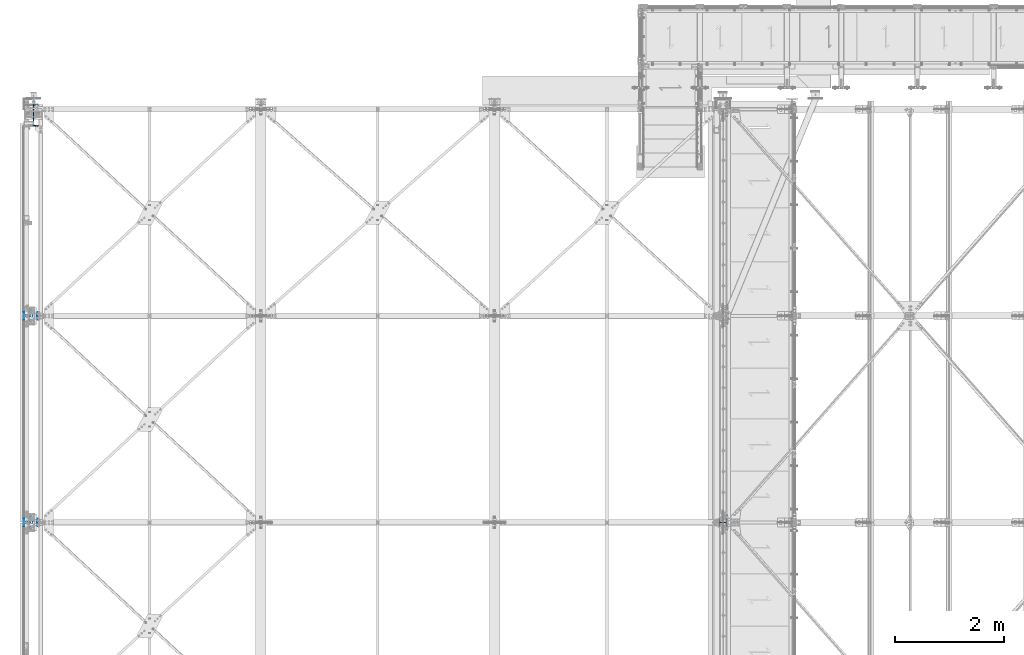
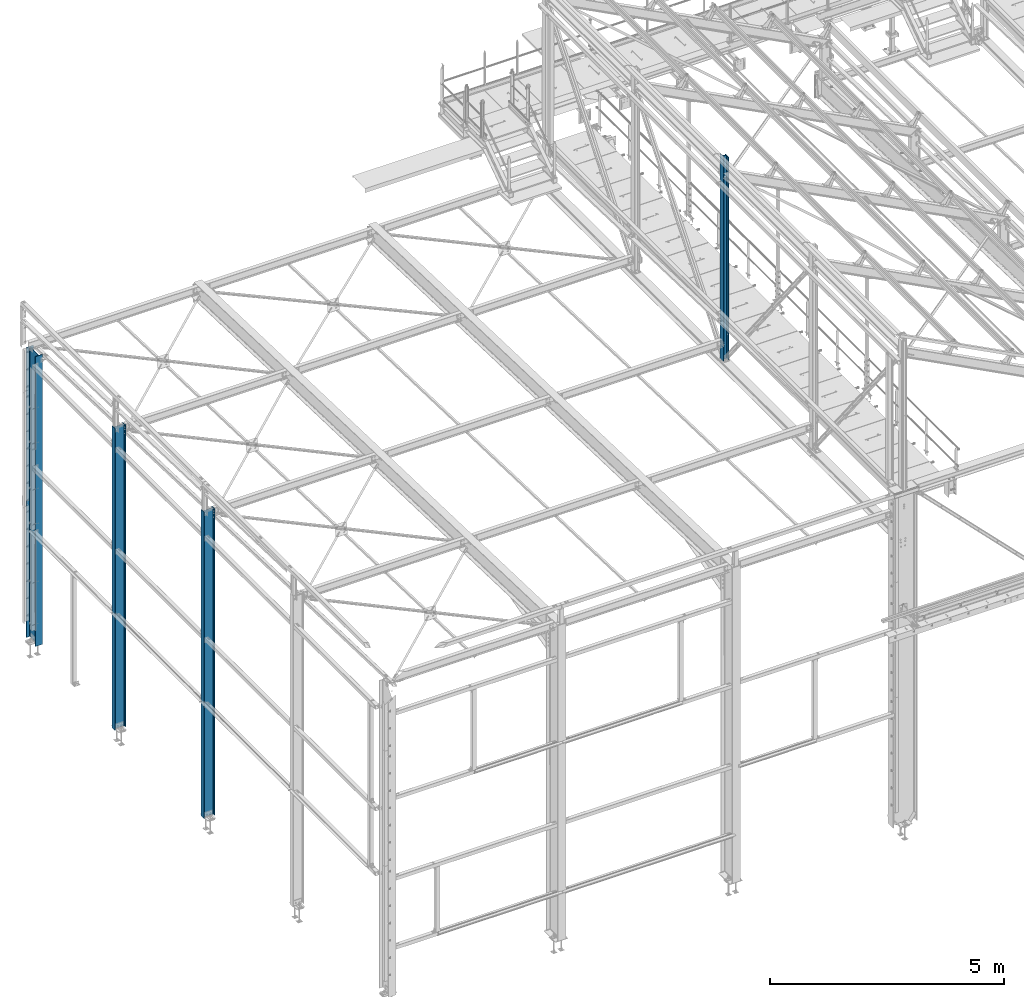
# One storey, part 5 of 496: 4 columns, 4 elements without a shape of their own.
"""IFC2X3 building model written with IfcOpenShell, lengths in millimetres."""

from ifc_helpers import new_model, si_unit, frame, origin_with_axes, origin_2d_with_axis, place, context, subcontext, project, spatial, i_section, extrude, clip, halfspace, material, type_object, element, aggregate, save


model = new_model("IFC2X3")

# Units and contexts
model_context = context("Model", 3, precision=1e-05, world=origin_with_axes())
body_context = subcontext(model_context, "Body", "Model", "MODEL_VIEW")
ifc_project = project(units=[si_unit("LENGTHUNIT", "METRE", prefix="MILLI"), si_unit("AREAUNIT", "SQUARE_METRE"), si_unit("VOLUMEUNIT", "CUBIC_METRE"), si_unit("MASSUNIT", "GRAM", prefix="KILO"), si_unit("TIMEUNIT", "SECOND"), si_unit("PLANEANGLEUNIT", "RADIAN"), si_unit("SOLIDANGLEUNIT", "STERADIAN"), si_unit("THERMODYNAMICTEMPERATUREUNIT", "DEGREE_CELSIUS"), si_unit("LUMINOUSINTENSITYUNIT", "LUMEN")], contexts=[model_context])

# Site, building, storey
site_placement = place(None, origin_with_axes())
site = spatial("IfcSite", under=ifc_project, at=site_placement, CompositionType="ELEMENT")
building_placement = place(site_placement, origin_with_axes())
building = spatial("IfcBuilding", under=site, at=building_placement, Name="Undefined", CompositionType="ELEMENT")
storey_placement = place(building_placement, origin_with_axes())
storey = spatial("IfcBuildingStorey", under=building, at=storey_placement, Name="Undefined", CompositionType="ELEMENT", Elevation=0.0)

# Assembly, column
assembly_1_placement = place(storey_placement, origin_with_axes())
assembly_1 = element("IfcElementAssembly", 1, at=assembly_1_placement, inside=storey, Name="MONTANT", AssemblyPlace="NOTDEFINED", PredefinedType="NOTDEFINED")
ifc_material = material(Name="Undefined/S275-E28")
column_type_1 = type_object("IfcColumnType", Name="HEA140", PredefinedType="NOTDEFINED")
column_1_placement = place(assembly_1_placement, frame((12680.0, 7600.0, 7260.0), z_axis=(0.0, 0.0, 1.0), x_axis=(-1.0, 0.0, 0.0)))
column_1 = element("IfcColumn", 2, at=column_1_placement, type_object=column_type_1, material=ifc_material, Name="MONTANT", ObjectType="HEA140", context=body_context, shape_type="Clipping", body=[
    clip(extrude(i_section(OverallWidth=140.0, OverallDepth=133.0, WebThickness=5.5, FlangeThickness=8.5, FilletRadius=12.0, at=origin_2d_with_axis()), frame((0.0, 0.0, 5353.83208547676), z_axis=(0.0, 0.0, -1.0), x_axis=(0.0, 1.0, 0.0)), (0.0, 0.0, 1.0), 5353.83), halfspace(frame((-66.5, 70.0, 5272.97130380653), z_axis=(-0.463528461042155, -7.08866187195592e-09, 0.886082031080583), x_axis=(0.886082031080583, 0.0, 0.463528461042155)), False)),
])
aggregate(assembly_1, [column_1])

assembly_2_placement = place(storey_placement, origin_with_axes())
assembly_2 = element("IfcElementAssembly", 3, at=assembly_2_placement, inside=storey, Name="POTEAU", AssemblyPlace="NOTDEFINED", PredefinedType="NOTDEFINED")
column_type_2 = type_object("IfcColumnType", Name="IPE270", PredefinedType="NOTDEFINED")
column_2_placement = place(assembly_2_placement, frame((-45.0, 7600.0, -180.0), z_axis=(0.0, 0.0, 1.0), x_axis=(-1.0, 0.0, 0.0)))
column_2 = element("IfcColumn", 4, at=column_2_placement, type_object=column_type_2, material=ifc_material, Name="POTEAU", ObjectType="IPE270", context=body_context, shape_type="SweptSolid", body=[
    extrude(i_section(OverallWidth=135.0, OverallDepth=270.0, WebThickness=6.599999905, FlangeThickness=10.19999981, FilletRadius=15.0, at=origin_2d_with_axis()), frame((0.0, 0.0, 7985.00041024081), z_axis=(0.0, 0.0, -1.0), x_axis=(0.0, 1.0, 0.0)), (0.0, 0.0, 1.0), 7985.0),
])
aggregate(assembly_2, [column_2])

assembly_3_placement = place(storey_placement, origin_with_axes())
assembly_3 = element("IfcElementAssembly", 5, at=assembly_3_placement, inside=storey, Name="POTEAU", AssemblyPlace="NOTDEFINED", PredefinedType="NOTDEFINED")
column_3_placement = place(assembly_3_placement, frame((-45.0, 11400.0, -180.0), z_axis=(0.0, 0.0, 1.0), x_axis=(-1.0, 0.0, 0.0)))
column_3 = element("IfcColumn", 6, at=column_3_placement, type_object=column_type_2, material=ifc_material, Name="POTEAU", ObjectType="IPE270", context=body_context, shape_type="SweptSolid", body=[
    extrude(i_section(OverallWidth=135.0, OverallDepth=270.0, WebThickness=6.599999905, FlangeThickness=10.19999981, FilletRadius=15.0, at=origin_2d_with_axis()), frame((0.0, 0.0, 7865.0013155368), z_axis=(0.0, 0.0, -1.0), x_axis=(0.0, 1.0, 0.0)), (0.0, 0.0, 1.0), 7865.0),
])
aggregate(assembly_3, [column_3])

assembly_4_placement = place(storey_placement, origin_with_axes())
assembly_4 = element("IfcElementAssembly", 7, at=assembly_4_placement, inside=storey, Name="POTEAU", AssemblyPlace="NOTDEFINED", PredefinedType="NOTDEFINED")
column_type_3 = type_object("IfcColumnType", Name="IPE400", PredefinedType="NOTDEFINED")
column_4_placement = place(assembly_4_placement, frame((6.54258599297464e-07, 15090.0000024006, -179.999999938862), z_axis=(0.0, 0.0, 1.0), x_axis=(0.0, -1.0, 0.0)))
column_4 = element("IfcColumn", 8, at=column_4_placement, type_object=column_type_3, material=ifc_material, Name="POTEAU", ObjectType="IPE400", context=body_context, shape_type="SweptSolid", body=[
    extrude(i_section(OverallWidth=180.0, OverallDepth=400.0, WebThickness=8.600000381, FlangeThickness=13.5, FilletRadius=21.0, at=origin_2d_with_axis()), frame((0.0, 0.0, 7549.99999999807), z_axis=(0.0, 0.0, -1.0), x_axis=(0.0, 1.0, 0.0)), (0.0, 0.0, 1.0), 7550.0),
])
aggregate(assembly_4, [column_4])

save(model, "model.ifc")
